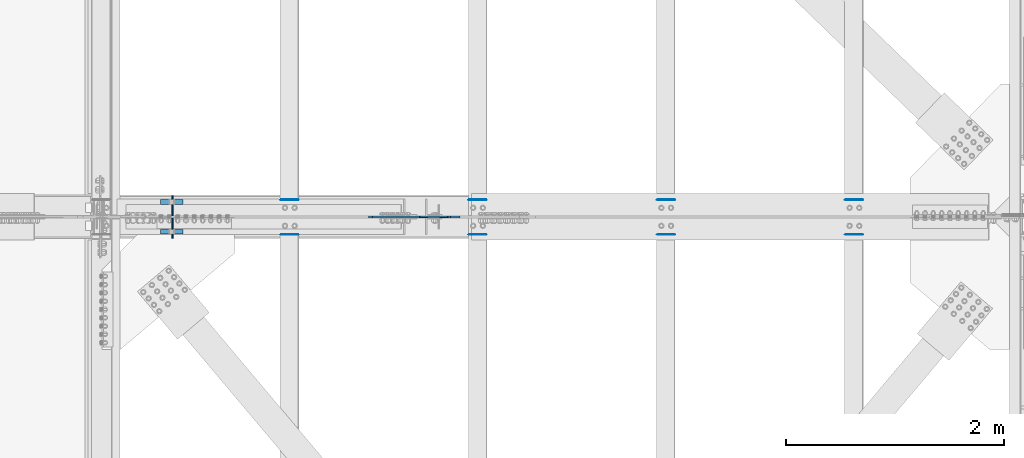
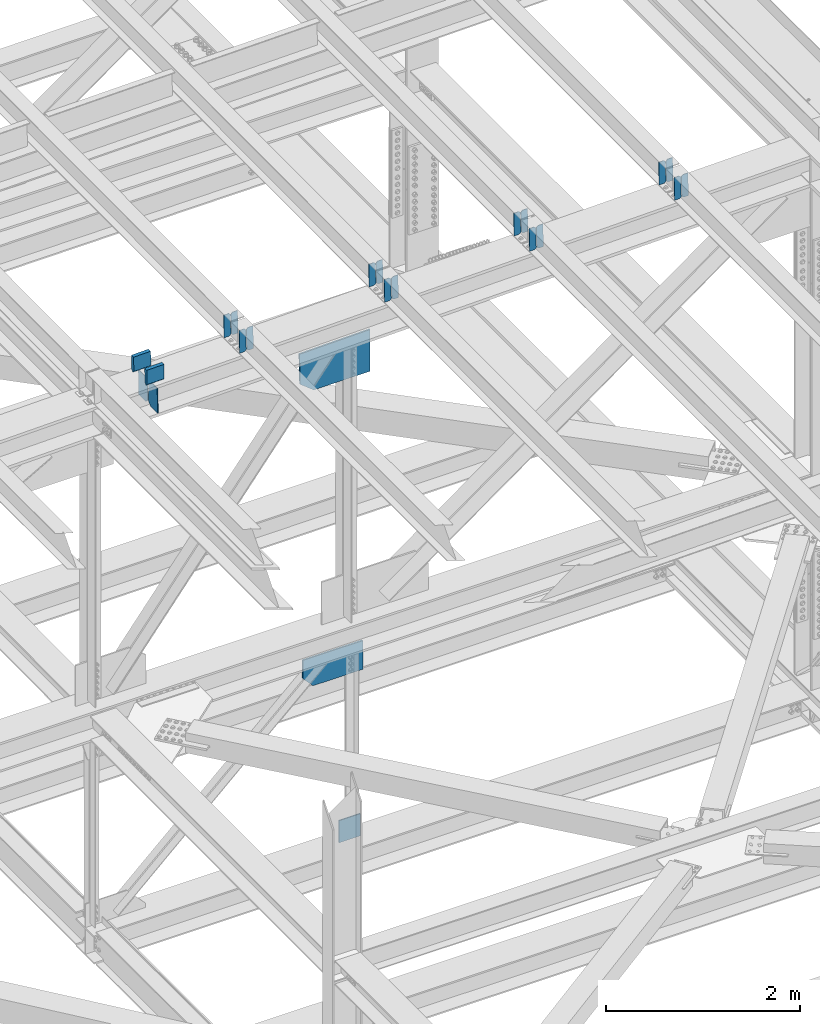
# One storey, part 3588 of 3843: 23 plates, 11 elements without a shape of their own.
"""IFC2X3 building model written with IfcOpenShell, lengths in millimetres."""

from ifc_helpers import new_model, si_unit, frame, origin_with_axes, place, context, subcontext, project, spatial, faceted_brep, material, type_object, element, aggregate, save


model = new_model("IFC2X3")

# Units and contexts
model_context = context("Model", 3, precision=1e-05, world=origin_with_axes())
body_context = subcontext(model_context, "Body", "Model", "MODEL_VIEW")
ifc_project = project(units=[si_unit("LENGTHUNIT", "METRE", prefix="MILLI"), si_unit("AREAUNIT", "SQUARE_METRE"), si_unit("VOLUMEUNIT", "CUBIC_METRE"), si_unit("MASSUNIT", "GRAM", prefix="KILO"), si_unit("TIMEUNIT", "SECOND"), si_unit("PLANEANGLEUNIT", "RADIAN"), si_unit("SOLIDANGLEUNIT", "STERADIAN"), si_unit("THERMODYNAMICTEMPERATUREUNIT", "DEGREE_CELSIUS"), si_unit("LUMINOUSINTENSITYUNIT", "LUMEN")], contexts=[model_context])

# Site, building, storey
site_placement = place(None, origin_with_axes())
site = spatial("IfcSite", under=ifc_project, at=site_placement, CompositionType="ELEMENT")
building_placement = place(site_placement, origin_with_axes())
building = spatial("IfcBuilding", under=site, at=building_placement, Name="Undefined", CompositionType="ELEMENT")
storey_placement = place(building_placement, origin_with_axes())
storey = spatial("IfcBuildingStorey", under=building, at=storey_placement, Name="Undefined", CompositionType="ELEMENT", Elevation=0.0)

# Assembly, plates
assembly_1_placement = place(storey_placement, origin_with_axes())
assembly_1 = element("IfcElementAssembly", 1, at=assembly_1_placement, inside=storey, Name="BEAM", AssemblyPlace="NOTDEFINED", PredefinedType="RIGID_FRAME")
ifc_material = material(Name="STEEL/A572-50")
plate_type_1 = type_object("IfcPlateType", PredefinedType="NOTDEFINED")
plate_1_placement = place(assembly_1_placement, frame((80549.4964783589, 34002.7072731097, 46381.2447812033), z_axis=(-0.0211520976960747, -0.00548809500152129, 0.999761206276934), x_axis=(-0.999776269345233, 0.000116185000071389, -0.0211517790072879)))
plate_1 = element("IfcPlate", 2, at=plate_1_placement, type_object=plate_type_1, material=ifc_material, Name="PLATE", context=body_context, shape_type="Brep", body=[
    faceted_brep([(0.0, -3.17499999999927, 0.0), (6.83940015733242e-10, -3.17499999996653, 288.924999998613), (6.54836185276508e-10, 3.17500000001746, 288.924999998591), (0.0, 3.17499999999927, 0.0), (60.3250007643655, -3.17500000017753, 288.924999998606), (60.3250007643219, 3.17499999979918, 288.924999998584), (79.3750000013097, -3.17500000025029, 269.875000761494), (79.375000001266, 3.17499999972642, 269.875000761487), (79.375000000713, -3.17500000026484, 19.0499992370605), (79.3750000006985, 3.17499999971187, 19.0499992370533), (60.325000763667, -3.17500000020664, -1.45519152283669e-11), (60.3250007636234, 3.17499999977736, -3.63797880709171e-11)], [[[0, 1, 2, 3]], [[1, 4, 5, 2]], [[4, 6, 7, 5]], [[6, 8, 9, 7]], [[8, 10, 11, 9]], [[10, 0, 3, 11]], [[5, 7, 9, 11, 3, 2]], [[10, 8, 6, 4, 1, 0]]]),
])
plate_2_placement = place(assembly_1_placement, frame((80463.7906576676, 34002.7172266993, 46379.431544921), z_axis=(-0.0211520976960747, -0.00548809500152129, 0.999761206276934), x_axis=(-0.999776269345233, 0.000116185000071389, -0.0211517790072879)))
plate_2 = element("IfcPlate", 3, at=plate_2_placement, type_object=plate_type_1, material=ifc_material, Name="PLATE", context=body_context, shape_type="Brep", body=[
    faceted_brep([(4.36557456851006e-11, -3.17499999998836, 19.0499992370969), (6.11180439591408e-10, -3.17499999996653, 269.875000761516), (5.96628524363041e-10, 3.17500000001746, 269.875000761502), (1.45519152283669e-11, 3.17499999998836, 19.0499992370824), (19.0499992376572, -3.17500000003201, 288.924999998606), (19.0499992376281, 3.1749999999447, 288.924999998584), (79.3750000013242, -3.17500000025029, 288.924999998591), (79.3750000013097, 3.1749999997337, 288.92499999857), (79.3750000006548, -3.17500000026484, -2.18278728425503e-11), (79.3750000006403, 3.17499999969732, -2.91038304567337e-11), (19.0499992370023, -3.17500000005384, 0.0), (19.0499992369587, 3.17499999992287, -1.45519152283669e-11)], [[[0, 1, 2, 3]], [[1, 4, 5, 2]], [[4, 6, 7, 5]], [[6, 8, 9, 7]], [[8, 10, 11, 9]], [[10, 0, 3, 11]], [[5, 7, 9, 11, 3, 2]], [[10, 8, 6, 4, 1, 0]]]),
])
aggregate(assembly_1, [plate_1, plate_2])

assembly_2_placement = place(storey_placement, origin_with_axes())
assembly_2 = element("IfcElementAssembly", 4, at=assembly_2_placement, inside=storey, Name="BEAM", AssemblyPlace="NOTDEFINED", PredefinedType="RIGID_FRAME")
plate_3_placement = place(assembly_2_placement, frame((80549.4964783507, 33684.3207431826, 46379.9791388136), z_axis=(-0.0211520979647176, -0.00249673099953362, 0.999773151812954), x_axis=(-0.999776269348143, 5.2822999999568e-05, -0.0211520320073443)))
plate_3 = element("IfcPlate", 5, at=plate_3_placement, type_object=plate_type_1, material=ifc_material, Name="PLATE", context=body_context, shape_type="Brep", body=[
    faceted_brep([(0.0, -3.17499999999927, 0.0), (6.83940015733242e-10, -3.17499999996653, 288.924999998613), (6.54836185276508e-10, 3.17500000001746, 288.924999998591), (0.0, 3.17499999999927, 0.0), (60.3250007643655, -3.17500000017753, 288.924999998606), (60.3250007643219, 3.17499999979918, 288.924999998584), (79.3750000013097, -3.17500000025029, 269.875000761494), (79.375000001266, 3.17499999972642, 269.875000761487), (79.375000000713, -3.17500000026484, 19.0499992370605), (79.3750000006985, 3.17499999971187, 19.0499992370533), (60.325000763667, -3.17500000020664, -1.45519152283669e-11), (60.3250007636234, 3.17499999977736, -3.63797880709171e-11)], [[[0, 1, 2, 3]], [[1, 4, 5, 2]], [[4, 6, 7, 5]], [[6, 8, 9, 7]], [[8, 10, 11, 9]], [[10, 0, 3, 11]], [[5, 7, 9, 11, 3, 2]], [[10, 8, 6, 4, 1, 0]]]),
])
plate_4_placement = place(assembly_2_placement, frame((80463.7906576605, 33684.3252714256, 46378.1658808672), z_axis=(-0.0211520979647176, -0.00249673099953362, 0.999773151812954), x_axis=(-0.999776269348143, 5.2822999999568e-05, -0.0211520320073443)))
plate_4 = element("IfcPlate", 6, at=plate_4_placement, type_object=plate_type_1, material=ifc_material, Name="PLATE", context=body_context, shape_type="Brep", body=[
    faceted_brep([(4.36557456851006e-11, -3.17499999998836, 19.0499992370969), (6.11180439591408e-10, -3.17499999996653, 269.875000761516), (5.96628524363041e-10, 3.17500000001746, 269.875000761502), (1.45519152283669e-11, 3.17499999998836, 19.0499992370824), (19.0499992376572, -3.17500000003201, 288.924999998606), (19.0499992376281, 3.1749999999447, 288.924999998584), (79.3750000013242, -3.17500000025029, 288.924999998591), (79.3750000013097, 3.1749999997337, 288.92499999857), (79.3750000006548, -3.17500000026484, -2.18278728425503e-11), (79.3750000006403, 3.17499999969732, -2.91038304567337e-11), (19.0499992370023, -3.17500000005384, 0.0), (19.0499992369587, 3.17499999992287, -1.45519152283669e-11)], [[[0, 1, 2, 3]], [[1, 4, 5, 2]], [[4, 6, 7, 5]], [[6, 8, 9, 7]], [[8, 10, 11, 9]], [[10, 0, 3, 11]], [[5, 7, 9, 11, 3, 2]], [[10, 8, 6, 4, 1, 0]]]),
])
aggregate(assembly_2, [plate_3, plate_4])

assembly_3_placement = place(storey_placement, origin_with_axes())
assembly_3 = element("IfcElementAssembly", 7, at=assembly_3_placement, inside=storey, Name="BEAM", AssemblyPlace="NOTDEFINED", PredefinedType="RIGID_FRAME")
plate_5_placement = place(assembly_3_placement, frame((84003.8964783501, 34002.3287909197, 46456.2100524493), z_axis=(-0.0211520977821637, -0.00421267500005342, 0.999767394011606), x_axis=(-0.999776269352005, 8.91270000423765e-05, -0.0211519100074729)))
plate_5 = element("IfcPlate", 8, at=plate_5_placement, type_object=plate_type_1, material=ifc_material, Name="PLATE", context=body_context, shape_type="Brep", body=[
    faceted_brep([(0.0, -3.17499999999927, 0.0), (6.83940015733242e-10, -3.17499999996653, 288.924999998613), (6.54836185276508e-10, 3.17500000001746, 288.924999998591), (0.0, 3.17499999999927, 0.0), (60.3250007643655, -3.17500000017753, 288.924999998606), (60.3250007643219, 3.17499999979918, 288.924999998584), (79.3750000013097, -3.17500000025029, 269.875000761494), (79.375000001266, 3.17499999972642, 269.875000761487), (79.375000000713, -3.17500000026484, 19.0499992370605), (79.3750000006985, 3.17499999971187, 19.0499992370533), (60.325000763667, -3.17500000020664, -1.45519152283669e-11), (60.3250007636234, 3.17499999977736, -3.63797880709171e-11)], [[[0, 1, 2, 3]], [[1, 4, 5, 2]], [[4, 6, 7, 5]], [[6, 8, 9, 7]], [[8, 10, 11, 9]], [[10, 0, 3, 11]], [[5, 7, 9, 11, 3, 2]], [[10, 8, 6, 4, 1, 0]]]),
])
plate_6_placement = place(assembly_3_placement, frame((83918.1906576589, 34002.3364313185, 46454.3968049448), z_axis=(-0.0211520977821637, -0.00421267500005342, 0.999767394011606), x_axis=(-0.999776269352005, 8.91270000423765e-05, -0.0211519100074729)))
plate_6 = element("IfcPlate", 9, at=plate_6_placement, type_object=plate_type_1, material=ifc_material, Name="PLATE", context=body_context, shape_type="Brep", body=[
    faceted_brep([(4.36557456851006e-11, -3.17499999998836, 19.0499992370969), (6.11180439591408e-10, -3.17499999996653, 269.875000761516), (5.96628524363041e-10, 3.17500000001746, 269.875000761502), (1.45519152283669e-11, 3.17499999998836, 19.0499992370824), (19.0499992376572, -3.17500000003201, 288.924999998606), (19.0499992376281, 3.1749999999447, 288.924999998584), (79.3750000013242, -3.17500000025029, 288.924999998591), (79.3750000013097, 3.1749999997337, 288.92499999857), (79.3750000006548, -3.17500000026484, -2.18278728425503e-11), (79.3750000006403, 3.17499999969732, -2.91038304567337e-11), (19.0499992370023, -3.17500000005384, 0.0), (19.0499992369587, 3.17499999992287, -1.45519152283669e-11)], [[[0, 1, 2, 3]], [[1, 4, 5, 2]], [[4, 6, 7, 5]], [[6, 8, 9, 7]], [[8, 10, 11, 9]], [[10, 0, 3, 11]], [[5, 7, 9, 11, 3, 2]], [[10, 8, 6, 4, 1, 0]]]),
])
aggregate(assembly_3, [plate_5, plate_6])

assembly_4_placement = place(storey_placement, origin_with_axes())
assembly_4 = element("IfcElementAssembly", 10, at=assembly_4_placement, inside=storey, Name="BEAM", AssemblyPlace="NOTDEFINED", PredefinedType="RIGID_FRAME")
plate_7_placement = place(assembly_4_placement, frame((84003.8964783511, 33684.3964508477, 46455.1060559436), z_axis=(-0.0211520980156492, -0.0027498239992492, 0.999772487727838), x_axis=(-0.999776269347066, 5.81780000294847e-05, -0.0211520180073662)))
plate_7 = element("IfcPlate", 11, at=plate_7_placement, type_object=plate_type_1, material=ifc_material, Name="PLATE", context=body_context, shape_type="Brep", body=[
    faceted_brep([(0.0, -3.17499999999927, 0.0), (6.83940015733242e-10, -3.17499999996653, 288.924999998613), (6.54836185276508e-10, 3.17500000001746, 288.924999998591), (0.0, 3.17499999999927, 0.0), (60.3250007643655, -3.17500000017753, 288.924999998606), (60.3250007643219, 3.17499999979918, 288.924999998584), (79.3750000013097, -3.17500000025029, 269.875000761494), (79.375000001266, 3.17499999972642, 269.875000761487), (79.375000000713, -3.17500000026484, 19.0499992370605), (79.3750000006985, 3.17499999971187, 19.0499992370533), (60.325000763667, -3.17500000020664, -1.45519152283669e-11), (60.3250007636234, 3.17499999977736, -3.63797880709171e-11)], [[[0, 1, 2, 3]], [[1, 4, 5, 2]], [[4, 6, 7, 5]], [[6, 8, 9, 7]], [[8, 10, 11, 9]], [[10, 0, 3, 11]], [[5, 7, 9, 11, 3, 2]], [[10, 8, 6, 4, 1, 0]]]),
])
plate_8_placement = place(assembly_4_placement, frame((83918.1906576599, 33684.4014381176, 46453.2927992015), z_axis=(-0.0211520980156492, -0.0027498239992492, 0.999772487727838), x_axis=(-0.999776269347066, 5.81780000294847e-05, -0.0211520180073662)))
plate_8 = element("IfcPlate", 12, at=plate_8_placement, type_object=plate_type_1, material=ifc_material, Name="PLATE", context=body_context, shape_type="Brep", body=[
    faceted_brep([(4.36557456851006e-11, -3.17499999998836, 19.0499992370969), (6.11180439591408e-10, -3.17499999996653, 269.875000761516), (5.96628524363041e-10, 3.17500000001746, 269.875000761502), (1.45519152283669e-11, 3.17499999998836, 19.0499992370824), (19.0499992376572, -3.17500000003201, 288.924999998606), (19.0499992376281, 3.1749999999447, 288.924999998584), (79.3750000013242, -3.17500000025029, 288.924999998591), (79.3750000013097, 3.1749999997337, 288.92499999857), (79.3750000006548, -3.17500000026484, -2.18278728425503e-11), (79.3750000006403, 3.17499999969732, -2.91038304567337e-11), (19.0499992370023, -3.17500000005384, 0.0), (19.0499992369587, 3.17499999992287, -1.45519152283669e-11)], [[[0, 1, 2, 3]], [[1, 4, 5, 2]], [[4, 6, 7, 5]], [[6, 8, 9, 7]], [[8, 10, 11, 9]], [[10, 0, 3, 11]], [[5, 7, 9, 11, 3, 2]], [[10, 8, 6, 4, 1, 0]]]),
])
aggregate(assembly_4, [plate_7, plate_8])

assembly_5_placement = place(storey_placement, origin_with_axes())
assembly_5 = element("IfcElementAssembly", 13, at=assembly_5_placement, inside=storey, Name="BEAM", AssemblyPlace="NOTDEFINED", PredefinedType="RIGID_FRAME")
plate_9_placement = place(assembly_5_placement, frame((82276.6964783647, 34002.5268217836, 46418.7319488474), z_axis=(-0.0211520979626948, -0.00487978700220265, 0.999764360452297), x_axis=(-0.999776269348186, 0.0001032410000617, -0.0211518460073737)))
plate_9 = element("IfcPlate", 14, at=plate_9_placement, type_object=plate_type_1, material=ifc_material, Name="PLATE", context=body_context, shape_type="Brep", body=[
    faceted_brep([(0.0, -3.17499999999927, 0.0), (6.83940015733242e-10, -3.17499999996653, 288.924999998613), (6.54836185276508e-10, 3.17500000001746, 288.924999998591), (0.0, 3.17499999999927, 0.0), (60.3250007643655, -3.17500000017753, 288.924999998606), (60.3250007643219, 3.17499999979918, 288.924999998584), (79.3750000013097, -3.17500000025029, 269.875000761494), (79.375000001266, 3.17499999972642, 269.875000761487), (79.375000000713, -3.17500000026484, 19.0499992370605), (79.3750000006985, 3.17499999971187, 19.0499992370533), (60.325000763667, -3.17500000020664, -1.45519152283669e-11), (60.3250007636234, 3.17499999977736, -3.63797880709171e-11)], [[[0, 1, 2, 3]], [[1, 4, 5, 2]], [[4, 6, 7, 5]], [[6, 8, 9, 7]], [[8, 10, 11, 9]], [[10, 0, 3, 11]], [[5, 7, 9, 11, 3, 2]], [[10, 8, 6, 4, 1, 0]]]),
])
plate_10_placement = place(assembly_5_placement, frame((82190.9906576734, 34002.5356721042, 46416.9187068438), z_axis=(-0.0211520979626948, -0.00487978700220265, 0.999764360452297), x_axis=(-0.999776269348186, 0.0001032410000617, -0.0211518460073737)))
plate_10 = element("IfcPlate", 15, at=plate_10_placement, type_object=plate_type_1, material=ifc_material, Name="PLATE", context=body_context, shape_type="Brep", body=[
    faceted_brep([(4.36557456851006e-11, -3.17499999998836, 19.0499992370969), (6.11180439591408e-10, -3.17499999996653, 269.875000761516), (5.96628524363041e-10, 3.17500000001746, 269.875000761502), (1.45519152283669e-11, 3.17499999998836, 19.0499992370824), (19.0499992376572, -3.17500000003201, 288.924999998606), (19.0499992376281, 3.1749999999447, 288.924999998584), (79.3750000013242, -3.17500000025029, 288.924999998591), (79.3750000013097, 3.1749999997337, 288.92499999857), (79.3750000006548, -3.17500000026484, -2.18278728425503e-11), (79.3750000006403, 3.17499999969732, -2.91038304567337e-11), (19.0499992370023, -3.17500000005384, 0.0), (19.0499992369587, 3.17499999992287, -1.45519152283669e-11)], [[[0, 1, 2, 3]], [[1, 4, 5, 2]], [[4, 6, 7, 5]], [[6, 8, 9, 7]], [[8, 10, 11, 9]], [[10, 0, 3, 11]], [[5, 7, 9, 11, 3, 2]], [[10, 8, 6, 4, 1, 0]]]),
])
aggregate(assembly_5, [plate_9, plate_10])

assembly_6_placement = place(storey_placement, origin_with_axes())
assembly_6 = element("IfcElementAssembly", 16, at=assembly_6_placement, inside=storey, Name="BEAM", AssemblyPlace="NOTDEFINED", PredefinedType="RIGID_FRAME")
plate_11_placement = place(assembly_6_placement, frame((82276.6964783511, 33684.3585939181, 46417.5425838924), z_axis=(-0.0211520978195331, -0.0026232759994382, 0.999772827786825), x_axis=(-0.999776269351215, 5.55000000252694e-05, -0.0211520250074752)))
plate_11 = element("IfcPlate", 17, at=plate_11_placement, type_object=plate_type_1, material=ifc_material, Name="PLATE", context=body_context, shape_type="Brep", body=[
    faceted_brep([(0.0, -3.17499999999927, 0.0), (6.83940015733242e-10, -3.17499999996653, 288.924999998613), (6.54836185276508e-10, 3.17500000001746, 288.924999998591), (0.0, 3.17499999999927, 0.0), (60.3250007643655, -3.17500000017753, 288.924999998606), (60.3250007643219, 3.17499999979918, 288.924999998584), (79.3750000013097, -3.17500000025029, 269.875000761494), (79.375000001266, 3.17499999972642, 269.875000761487), (79.375000000713, -3.17500000026484, 19.0499992370605), (79.3750000006985, 3.17499999971187, 19.0499992370533), (60.325000763667, -3.17500000020664, -1.45519152283669e-11), (60.3250007636234, 3.17499999977736, -3.63797880709171e-11)], [[[0, 1, 2, 3]], [[1, 4, 5, 2]], [[4, 6, 7, 5]], [[6, 8, 9, 7]], [[8, 10, 11, 9]], [[10, 0, 3, 11]], [[5, 7, 9, 11, 3, 2]], [[10, 8, 6, 4, 1, 0]]]),
])
plate_12_placement = place(assembly_6_placement, frame((82190.9906576599, 33684.3633516741, 46415.7293265333), z_axis=(-0.0211520978195331, -0.0026232759994382, 0.999772827786825), x_axis=(-0.999776269351215, 5.55000000252694e-05, -0.0211520250074752)))
plate_12 = element("IfcPlate", 18, at=plate_12_placement, type_object=plate_type_1, material=ifc_material, Name="PLATE", context=body_context, shape_type="Brep", body=[
    faceted_brep([(4.36557456851006e-11, -3.17499999998836, 19.0499992370969), (6.11180439591408e-10, -3.17499999996653, 269.875000761516), (5.96628524363041e-10, 3.17500000001746, 269.875000761502), (1.45519152283669e-11, 3.17499999998836, 19.0499992370824), (19.0499992376572, -3.17500000003201, 288.924999998606), (19.0499992376281, 3.1749999999447, 288.924999998584), (79.3750000013242, -3.17500000025029, 288.924999998591), (79.3750000013097, 3.1749999997337, 288.92499999857), (79.3750000006548, -3.17500000026484, -2.18278728425503e-11), (79.3750000006403, 3.17499999969732, -2.91038304567337e-11), (19.0499992370023, -3.17500000005384, 0.0), (19.0499992369587, 3.17499999992287, -1.45519152283669e-11)], [[[0, 1, 2, 3]], [[1, 4, 5, 2]], [[4, 6, 7, 5]], [[6, 8, 9, 7]], [[8, 10, 11, 9]], [[10, 0, 3, 11]], [[5, 7, 9, 11, 3, 2]], [[10, 8, 6, 4, 1, 0]]]),
])
aggregate(assembly_6, [plate_11, plate_12])

assembly_7_placement = place(storey_placement, origin_with_axes())
assembly_7 = element("IfcElementAssembly", 19, at=assembly_7_placement, inside=storey, Name="BEAM", AssemblyPlace="NOTDEFINED", PredefinedType="RIGID_FRAME")
plate_13_placement = place(assembly_7_placement, frame((78822.2964783594, 34002.8043628291, 46344.7547830839), z_axis=(-0.0211520978613553, -0.0058155520005821, 0.999759355100512), x_axis=(-0.99977626935033, 0.000123039000078619, -0.0211517400074097)))
plate_13 = element("IfcPlate", 20, at=plate_13_placement, type_object=plate_type_1, material=ifc_material, Name="PLATE", context=body_context, shape_type="Brep", body=[
    faceted_brep([(0.0, -3.17499999999927, 0.0), (6.83940015733242e-10, -3.17499999996653, 288.924999998613), (6.54836185276508e-10, 3.17500000001746, 288.924999998591), (0.0, 3.17499999999927, 0.0), (60.3250007643655, -3.17500000017753, 288.924999998606), (60.3250007643219, 3.17499999979918, 288.924999998584), (79.3750000013097, -3.17500000025029, 269.875000761494), (79.375000001266, 3.17499999972642, 269.875000761487), (79.375000000713, -3.17500000026484, 19.0499992370605), (79.3750000006985, 3.17499999971187, 19.0499992370533), (60.325000763667, -3.17500000020664, -1.45519152283669e-11), (60.3250007636234, 3.17499999977736, -3.63797880709171e-11)], [[[0, 1, 2, 3]], [[1, 4, 5, 2]], [[4, 6, 7, 5]], [[6, 8, 9, 7]], [[8, 10, 11, 9]], [[10, 0, 3, 11]], [[5, 7, 9, 11, 3, 2]], [[10, 8, 6, 4, 1, 0]]]),
])
plate_14_placement = place(assembly_7_placement, frame((78736.5906576681, 34002.8149103167, 46342.94155016), z_axis=(-0.0211520978613553, -0.0058155520005821, 0.999759355100512), x_axis=(-0.99977626935033, 0.000123039000078619, -0.0211517400074097)))
plate_14 = element("IfcPlate", 21, at=plate_14_placement, type_object=plate_type_1, material=ifc_material, Name="PLATE", context=body_context, shape_type="Brep", body=[
    faceted_brep([(4.36557456851006e-11, -3.17499999998836, 19.0499992370969), (6.11180439591408e-10, -3.17499999996653, 269.875000761516), (5.96628524363041e-10, 3.17500000001746, 269.875000761502), (1.45519152283669e-11, 3.17499999998836, 19.0499992370824), (19.0499992376572, -3.17500000003201, 288.924999998606), (19.0499992376281, 3.1749999999447, 288.924999998584), (79.3750000013242, -3.17500000025029, 288.924999998591), (79.3750000013097, 3.1749999997337, 288.92499999857), (79.3750000006548, -3.17500000026484, -2.18278728425503e-11), (79.3750000006403, 3.17499999969732, -2.91038304567337e-11), (19.0499992370023, -3.17500000005384, 0.0), (19.0499992369587, 3.17499999992287, -1.45519152283669e-11)], [[[0, 1, 2, 3]], [[1, 4, 5, 2]], [[4, 6, 7, 5]], [[6, 8, 9, 7]], [[8, 10, 11, 9]], [[10, 0, 3, 11]], [[5, 7, 9, 11, 3, 2]], [[10, 8, 6, 4, 1, 0]]]),
])
aggregate(assembly_7, [plate_13, plate_14])

assembly_8_placement = place(storey_placement, origin_with_axes())
assembly_8 = element("IfcElementAssembly", 22, at=assembly_8_placement, inside=storey, Name="BEAM", AssemblyPlace="NOTDEFINED", PredefinedType="RIGID_FRAME")
plate_15_placement = place(assembly_8_placement, frame((78822.2964783516, 33684.3207431827, 46343.4370595535), z_axis=(-0.0211520979647176, -0.00249673099953362, 0.999773151812954), x_axis=(-0.999776269348143, 5.2822999999568e-05, -0.0211520320073443)))
plate_15 = element("IfcPlate", 23, at=plate_15_placement, type_object=plate_type_1, material=ifc_material, Name="PLATE", context=body_context, shape_type="Brep", body=[
    faceted_brep([(0.0, -3.17499999999927, 0.0), (6.83940015733242e-10, -3.17499999996653, 288.924999998613), (6.54836185276508e-10, 3.17500000001746, 288.924999998591), (0.0, 3.17499999999927, 0.0), (60.3250007643655, -3.17500000017753, 288.924999998606), (60.3250007643219, 3.17499999979918, 288.924999998584), (79.3750000013097, -3.17500000025029, 269.875000761494), (79.375000001266, 3.17499999972642, 269.875000761487), (79.375000000713, -3.17500000026484, 19.0499992370605), (79.3750000006985, 3.17499999971187, 19.0499992370533), (60.325000763667, -3.17500000020664, -1.45519152283669e-11), (60.3250007636234, 3.17499999977736, -3.63797880709171e-11)], [[[0, 1, 2, 3]], [[1, 4, 5, 2]], [[4, 6, 7, 5]], [[6, 8, 9, 7]], [[8, 10, 11, 9]], [[10, 0, 3, 11]], [[5, 7, 9, 11, 3, 2]], [[10, 8, 6, 4, 1, 0]]]),
])
plate_16_placement = place(assembly_8_placement, frame((78736.5906576604, 33684.3252714255, 46341.6238016071), z_axis=(-0.0211520979647176, -0.00249673099953362, 0.999773151812954), x_axis=(-0.999776269348143, 5.2822999999568e-05, -0.0211520320073443)))
plate_16 = element("IfcPlate", 24, at=plate_16_placement, type_object=plate_type_1, material=ifc_material, Name="PLATE", context=body_context, shape_type="Brep", body=[
    faceted_brep([(4.36557456851006e-11, -3.17499999998836, 19.0499992370969), (6.11180439591408e-10, -3.17499999996653, 269.875000761516), (5.96628524363041e-10, 3.17500000001746, 269.875000761502), (1.45519152283669e-11, 3.17499999998836, 19.0499992370824), (19.0499992376572, -3.17500000003201, 288.924999998606), (19.0499992376281, 3.1749999999447, 288.924999998584), (79.3750000013242, -3.17500000025029, 288.924999998591), (79.3750000013097, 3.1749999997337, 288.92499999857), (79.3750000006548, -3.17500000026484, -2.18278728425503e-11), (79.3750000006403, 3.17499999969732, -2.91038304567337e-11), (19.0499992370023, -3.17500000005384, 0.0), (19.0499992369587, 3.17499999992287, -1.45519152283669e-11)], [[[0, 1, 2, 3]], [[1, 4, 5, 2]], [[4, 6, 7, 5]], [[6, 8, 9, 7]], [[8, 10, 11, 9]], [[10, 0, 3, 11]], [[5, 7, 9, 11, 3, 2]], [[10, 8, 6, 4, 1, 0]]]),
])
aggregate(assembly_8, [plate_15, plate_16])

assembly_9_placement = place(storey_placement, origin_with_axes())
assembly_9 = element("IfcElementAssembly", 25, at=assembly_9_placement, inside=storey, Name="BEAM", AssemblyPlace="NOTDEFINED", PredefinedType="RIGID_FRAME")
plate_type_2 = type_object("IfcPlateType", PredefinedType="NOTDEFINED")
plate_17_placement = place(assembly_9_placement, frame((77667.3811912228, 33650.2375, 45951.8810674898), z_axis=(-0.0216342480057937, 0.0, 0.999765952267441), x_axis=(0.0, 1.0, 0.0)))
plate_17 = element("IfcPlate", 26, at=plate_17_placement, type_object=plate_type_2, material=ifc_material, Name="PL", context=body_context, shape_type="Brep", body=[
    faceted_brep([(0.0, -4.76249999999709, 0.0), (0.0, -4.76249999785796, 317.500000005042), (0.0, 4.76250000210712, 317.50000000505), (0.0, 4.76249999999709, 0.0), (146.050001525873, -4.76249999785796, 317.500000005042), (146.050001525873, 4.76250000210712, 317.50000000505), (184.149999999994, -4.76249999810534, 279.400001530797), (184.149999999994, 4.76250000185973, 279.400001530805), (184.149999999994, -4.7624999997206, 38.0999984742448), (184.149999999994, 4.76250000022992, 38.0999984742448), (146.049999999988, -4.76250000000073, 0.0), (146.049999999988, 4.76250000000073, 0.0)], [[[0, 1, 2, 3]], [[1, 4, 5, 2]], [[4, 6, 7, 5]], [[6, 8, 9, 7]], [[8, 10, 11, 9]], [[10, 0, 3, 11]], [[5, 7, 9, 11, 3, 2]], [[10, 8, 6, 4, 1, 0]]]),
])
plate_18_placement = place(assembly_9_placement, frame((77667.3811912228, 33856.6125, 45951.8810674898), z_axis=(-0.0216342480057937, 0.0, 0.999765952267441), x_axis=(0.0, 1.0, 0.0)))
plate_18 = element("IfcPlate", 27, at=plate_18_placement, type_object=plate_type_2, material=ifc_material, Name="PL", context=body_context, shape_type="Brep", body=[
    faceted_brep([(0.0, -4.76250000000073, 38.0999999999985), (0.0, -4.76249999810534, 279.400001530797), (0.0, 4.76250000185973, 279.400001530805), (0.0, 4.76250000000073, 38.0999999999985), (38.0999984741211, -4.76249999785796, 317.500000005042), (38.0999984741211, 4.76250000210712, 317.50000000505), (184.150000000009, -4.76249999999709, 317.5), (184.150000000009, 4.76249999999709, 317.5), (184.150000000009, -4.76249999999709, 0.0), (184.150000000009, 4.76249999999709, 0.0), (38.0999984741211, -4.76249999996799, 0.0), (38.0999984741211, 4.76249999998254, 0.0)], [[[0, 1, 2, 3]], [[1, 4, 5, 2]], [[4, 6, 7, 5]], [[6, 8, 9, 7]], [[8, 10, 11, 9]], [[10, 0, 3, 11]], [[5, 7, 9, 11, 3, 2]], [[10, 8, 6, 4, 1, 0]]]),
])
plate_type_3 = type_object("IfcPlateType", PredefinedType="NOTDEFINED")
plate_19_placement = place(assembly_9_placement, frame((77554.0361726478, 33981.628125, 46508.2774287603), z_axis=(0.0217666070074993, 0.0, -0.999763079343992), x_axis=(0.999763079343992, 0.0, 0.0217666070075027)))
plate_19 = element("IfcPlate", 28, at=plate_19_placement, type_object=plate_type_3, material=ifc_material, Name="PLATE", context=body_context, shape_type="Brep", body=[
    faceted_brep([(203.200005058941, -22.2250000000058, -1.16415321826935e-10), (7.27595761418343e-12, -22.2250000000058, -7.27595761418343e-12), (7.27595761418343e-12, 22.2250000000058, -7.27595761418343e-12), (203.200005058941, 22.2250000000058, -1.16415321826935e-10), (203.838531807472, -22.2250000000058, 0.00187068080413155), (203.838531807472, 22.2250000000058, 0.00187068080413155), (203.310341304641, -22.2250000000058, 180.861817383484), (0.04046799018397, -22.2250000000058, 180.907287948779), (203.245434494536, 0.0133131837355904, 203.086833080139), (0.0454396034692763, 0.0133129994646879, 203.132287829787), (0.0404679902494536, 22.2250000000058, 180.907288225317), (203.310341303353, 22.2250000000058, 180.861817822159)], [[[0, 1, 2, 3]], [[4, 0, 3, 5]], [[1, 0, 4, 6, 7]], [[7, 6, 8, 9]], [[2, 1, 7, 9, 10]], [[5, 3, 2, 10, 11]], [[6, 4, 5, 11, 8]], [[10, 9, 8, 11]]]),
])
plate_20_placement = place(assembly_9_placement, frame((77554.0361726478, 33708.578125, 46508.2774287603), z_axis=(0.0217666070074993, 0.0, -0.999763079343992), x_axis=(0.999763079343992, 0.0, 0.0217666070075027)))
plate_20 = element("IfcPlate", 29, at=plate_20_placement, type_object=plate_type_3, material=ifc_material, Name="PLATE", context=body_context, shape_type="Brep", body=[
    faceted_brep([(203.200005058941, -22.2250000000058, -1.16415321826935e-10), (7.27595761418343e-12, -22.2250000000058, -7.27595761418343e-12), (7.27595761418343e-12, 22.2250000000058, -7.27595761418343e-12), (203.200005058941, 22.2250000000058, -1.16415321826935e-10), (203.838531807472, -22.2250000000058, 0.00187068080413155), (203.838531807472, 22.2250000000058, 0.00187068080413155), (203.310341304641, -22.2250000000058, 180.861817383484), (0.04046799018397, -22.2250000000058, 180.907287948779), (203.245434494536, 0.0133131837355904, 203.086833080139), (0.0454396034692763, 0.0133129994646879, 203.132287829787), (0.0404679902494536, 22.2250000000058, 180.907288225317), (203.310341303353, 22.2250000000058, 180.861817822159)], [[[0, 1, 2, 3]], [[4, 0, 3, 5]], [[1, 0, 4, 6, 7]], [[7, 6, 8, 9]], [[2, 1, 7, 9, 10]], [[5, 3, 2, 10, 11]], [[6, 4, 5, 11, 8]], [[10, 9, 8, 11]]]),
])

# Assembly, plate
assembly_10_placement = place(storey_placement, origin_with_axes())
assembly_10 = element("IfcElementAssembly", 30, at=assembly_10_placement, inside=storey, Name="BEAM", AssemblyPlace="NOTDEFINED", PredefinedType="RIGID_FRAME")
plate_type_4 = type_object("IfcPlateType", PredefinedType="NOTDEFINED")
plate_21_placement = place(assembly_10_placement, frame((80188.5552016201, 33845.5000007629, 39632.866398919), z_axis=(-0.002704930999098, 0.0, 0.999996341667453), x_axis=(-0.999996341667453, 0.0, -0.00270493099909521)))
plate_21 = element("IfcPlate", 31, at=plate_21_placement, type_object=plate_type_4, material=ifc_material, Name="PLATE", context=body_context, shape_type="Brep", body=[
    faceted_brep([(0.0, -6.3499999046162, 0.0), (5.23868948221207e-10, -6.35000000000582, 279.192955034581), (5.23868948221207e-10, 6.35000000000582, 279.192955034581), (7.27595761418343e-12, 6.3499999046162, 0.0), (253.999070822829, -6.35000000000582, 279.880007507963), (253.999070822829, 6.35000000000582, 279.880007507963), (254.756129700181, -6.35000000000582, -4.94765117764473e-10), (254.756129700181, 6.35000000000582, -4.94765117764473e-10)], [[[0, 1, 2, 3]], [[1, 4, 5, 2]], [[4, 6, 7, 5]], [[6, 0, 3, 7]], [[5, 7, 3, 2]], [[6, 4, 1, 0]]]),
])
aggregate(assembly_10, [plate_21])

assembly_11_placement = place(storey_placement, origin_with_axes())
assembly_11 = element("IfcElementAssembly", 32, at=assembly_11_placement, inside=storey, Name="BEAM", AssemblyPlace="NOTDEFINED", PredefinedType="RIGID_FRAME")
plate_type_5 = type_object("IfcPlateType", PredefinedType="NOTDEFINED")
plate_22_placement = place(assembly_11_placement, frame((80213.0282636309, 33845.5, 42083.4685927786), z_axis=(0.000482814000206417, 0.0, -0.999999883445314), x_axis=(-0.999999883445314, 0.0, -0.000482814000210543)))
plate_22 = element("IfcPlate", 33, at=plate_22_placement, type_object=plate_type_5, material=ifc_material, Name="PLATE", context=body_context, shape_type="Brep", body=[
    faceted_brep([(0.0, -9.52500000000146, 0.0), (8.87666828930378e-10, -9.52500000000146, 362.048068762786), (8.87666828930378e-10, 9.52500000000146, 362.048068762786), (0.0, 9.52500000000146, 0.0), (592.565345507202, -9.52500000000146, 361.470338337364), (592.565345507202, 9.52500000000146, 361.470338337364), (713.274509915631, -9.52500000000146, 230.924798648899), (713.274509915631, 9.52500000000146, 230.924798648899), (713.274509915049, -9.52500000000146, -1.81898940354586e-09), (713.274509915049, 9.52500000000146, -1.81898940354586e-09)], [[[0, 1, 2, 3]], [[1, 4, 5, 2]], [[4, 6, 7, 5]], [[6, 8, 9, 7]], [[8, 0, 3, 9]], [[5, 7, 9, 3, 2]], [[8, 6, 4, 1, 0]]]),
])
aggregate(assembly_11, [plate_22])

# Plate
plate_type_6 = type_object("IfcPlateType", PredefinedType="NOTDEFINED")
plate_23_placement = place(assembly_9_placement, frame((80302.1000000052, 33845.5, 45970.7856548376), z_axis=(0.0216342480057937, 0.0, -0.999765952267441), x_axis=(-0.999765952267441, 0.0, -0.0216342480057875)))
plate_23 = element("IfcPlate", 34, at=plate_23_placement, type_object=plate_type_6, material=ifc_material, Name="PLATE", context=body_context, shape_type="Brep", body=[
    faceted_brep([(0.0, -9.52500000000146, 0.0), (11.3849834193243, -9.52500000000146, 526.124978314932), (11.3849834193243, 9.52500000000146, 526.124978314932), (0.0, 9.52500000000146, 0.0), (685.138326404965, -9.52500000000146, 511.545418410402), (685.138326404965, 9.52500000000146, 511.545418410402), (842.440118648854, -9.52500000000146, 382.912659571579), (842.440118648854, 9.52500000000146, 382.912659571579), (842.440118647603, -9.52500000000146, -2.77941580861807e-09), (842.440118647603, 9.52500000000146, -2.77941580861807e-09)], [[[0, 1, 2, 3]], [[1, 4, 5, 2]], [[4, 6, 7, 5]], [[6, 8, 9, 7]], [[8, 0, 3, 9]], [[5, 7, 9, 3, 2]], [[8, 6, 4, 1, 0]]]),
])

aggregate(assembly_9, [plate_17, plate_18, plate_19, plate_20, plate_23])

save(model, "model.ifc")
